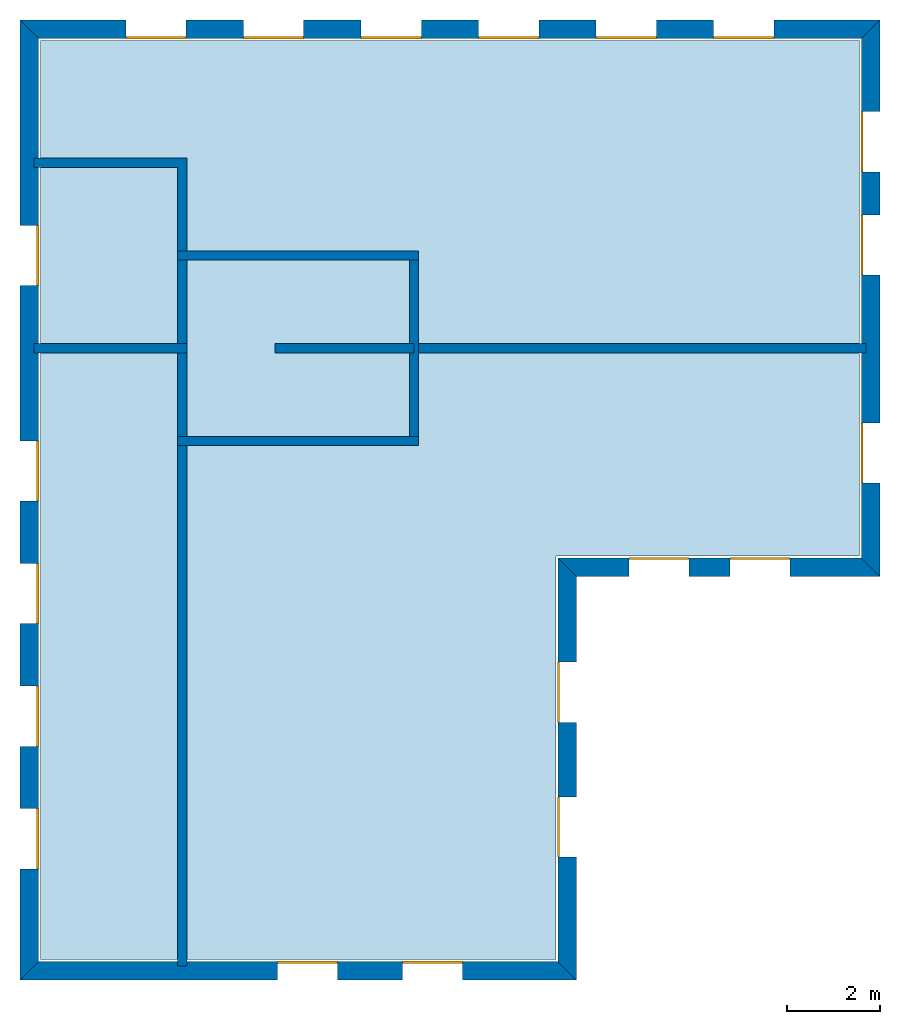
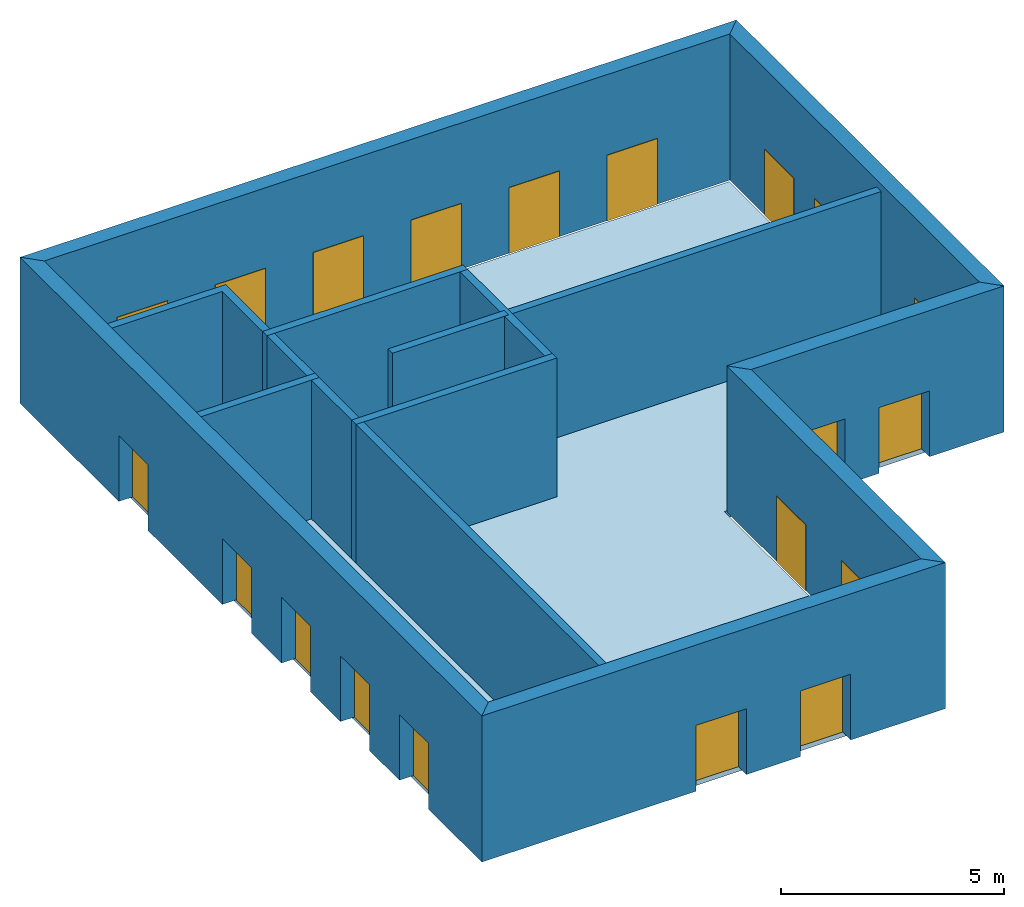
# One storey: 20 windows, 15 walls, 1 slab, 20 openings.
"""IFC4 building model written with IfcOpenShell, lengths in metres."""

import ifcopenshell
import ifcopenshell.guid

model = None  # the IFC model being written
_history = None  # IfcOwnerHistory: only IFC2X3 demands one
_inside = {}  # id of a spatial element -> (the spatial element, [elements in it])
_under = {}  # id of a project, library or spatial element -> (it, [spatial elements below it])
_declared = {}  # id of a project -> (the project, [libraries it declares])
_typed = {}  # id of a type object -> (the type object, [elements of that type])
_made_of = {}  # id of a material, layer set ... -> (it, [elements and type objects made of it])


def new_model(schema):
    """Start an empty IFC model of exactly this schema.

    Asked for "IFC4X3", IfcOpenShell would pick the latest addendum, in which some entities
    have other attributes; the version numbers below select the first issue.
    IFC2X3 requires an IfcOwnerHistory on every rooted entity: one is made here for all.
    """
    global model, _history
    if schema == "IFC4X3":
        model = ifcopenshell.file(schema_version=(4, 3, 0, 0))
    else:
        model = ifcopenshell.file(schema=schema)
    _inside.clear()
    _under.clear()
    _declared.clear()
    _typed.clear()
    _made_of.clear()
    _history = None
    if model.schema == "IFC2X3":
        org = make("IfcOrganization", Name="unknown")
        user = make(
            "IfcPersonAndOrganization",
            ThePerson=make("IfcPerson", FamilyName="unknown"),
            TheOrganization=org,
        )
        app = make(
            "IfcApplication",
            ApplicationDeveloper=org,
            Version="unknown",
            ApplicationFullName="unknown",
            ApplicationIdentifier="unknown",
        )
        _history = make(
            "IfcOwnerHistory",
            OwningUser=user,
            OwningApplication=app,
            ChangeAction="ADDED",
            CreationDate=0,
        )
    return model


def make(cls, **values):
    """One entity of the class cls with the attributes given. An attribute that is None is left unset."""
    return model.create_entity(
        cls, **{name: value for name, value in values.items() if value is not None}
    )


def rooted(cls, **values):
    """An entity with a GlobalId (a new one), such as an element, a storey or a relation."""
    return make(cls, GlobalId=ifcopenshell.guid.new(), OwnerHistory=_history, **values)


def si_unit(unit_type, name, prefix=None):
    """IfcSIUnit, for example si_unit("LENGTHUNIT", "METRE", prefix="MILLI")."""
    return make("IfcSIUnit", UnitType=unit_type, Prefix=prefix, Name=name)


def assignment(units):
    """IfcUnitAssignment: the units of a project."""
    return None if units is None else make("IfcUnitAssignment", Units=units)


def point(xyz):
    """IfcCartesianPoint."""
    return None if xyz is None else make("IfcCartesianPoint", Coordinates=xyz)


def direction(xyz):
    """IfcDirection."""
    return None if xyz is None else make("IfcDirection", DirectionRatios=xyz)


def frame(location, z_axis=None, x_axis=None):
    """IfcAxis2Placement3D, a coordinate frame: its origin and axes. An axis left out is left unset."""
    return make(
        "IfcAxis2Placement3D",
        Location=point(location),
        Axis=direction(z_axis),
        RefDirection=direction(x_axis),
    )


def origin_with_axes():
    """The frame at (0, 0, 0) with the z axis (0, 0, 1) and the x axis (1, 0, 0) written out."""
    return frame((0.0, 0.0, 0.0), z_axis=(0.0, 0.0, 1.0), x_axis=(1.0, 0.0, 0.0))


def place(relative_to, where):
    """IfcLocalPlacement: puts the frame where relative to a parent placement (None: the world)."""
    return make(
        "IfcLocalPlacement", PlacementRelTo=relative_to, RelativePlacement=where
    )


def context(
    kind, dimensions, precision=None, world=None, true_north=None, identifier=None
):
    """IfcGeometricRepresentationContext, for example the 3D "Model" context."""
    return make(
        "IfcGeometricRepresentationContext",
        ContextIdentifier=identifier,
        ContextType=kind,
        CoordinateSpaceDimension=dimensions,
        Precision=precision,
        WorldCoordinateSystem=world,
        TrueNorth=true_north,
    )


def subcontext(parent, identifier, kind, view, scale=None):
    """IfcGeometricRepresentationSubContext, for example "Body" below "Model"."""
    return make(
        "IfcGeometricRepresentationSubContext",
        ContextIdentifier=identifier,
        ContextType=kind,
        ParentContext=parent,
        TargetScale=scale,
        TargetView=view,
    )


def project(units=None, contexts=None):
    """IfcProject with its units and contexts."""
    return rooted(
        "IfcProject",
        Name="project",
        RepresentationContexts=contexts,
        UnitsInContext=assignment(units),
    )


def spatial(cls, under=None, at=None, **own):
    """A site, building, storey or space (cls), placed at a placement, below another one or the project."""
    s = rooted(cls, ObjectPlacement=at, **own)
    if under is not None:
        _under.setdefault(under.id(), (under, []))[1].append(s)
    return s


def point_list(points):
    """IfcCartesianPointList2D or 3D."""
    cls = (
        "IfcCartesianPointList2D" if len(points[0]) == 2 else "IfcCartesianPointList3D"
    )
    return make(cls, CoordList=points)


def line(*indices):
    """IfcLineIndex: a straight run through numbered points of an indexed curve."""
    return model.create_entity("IfcLineIndex", indices)


def indexed_curve(points, segments=None, self_intersect=None):
    """IfcIndexedPolyCurve: lines and arcs through numbered points (the first is 1)."""
    return make(
        "IfcIndexedPolyCurve",
        Points=point_list(points),
        Segments=segments,
        SelfIntersect=self_intersect,
    )


def outline(outer, holes=None, kind="AREA"):
    """IfcArbitraryClosedProfileDef: a profile drawn as a closed curve; with holes, ...WithVoids."""
    if holes is None:
        return make("IfcArbitraryClosedProfileDef", ProfileType=kind, OuterCurve=outer)
    return make(
        "IfcArbitraryProfileDefWithVoids",
        ProfileType=kind,
        OuterCurve=outer,
        InnerCurves=holes,
    )


def extrude(swept, where, along, depth):
    """IfcExtrudedAreaSolid: the profile swept, set in the frame where, extruded along a direction by depth."""
    return make(
        "IfcExtrudedAreaSolid",
        SweptArea=swept,
        Position=where,
        ExtrudedDirection=direction(along),
        Depth=depth,
    )


def shape(context_of_items, identifier, shape_type, items):
    """IfcShapeRepresentation: the items that make up one representation, for example the "Body"."""
    return make(
        "IfcShapeRepresentation",
        ContextOfItems=context_of_items,
        RepresentationIdentifier=identifier,
        RepresentationType=shape_type,
        Items=items,
    )


def made_of(thing, what):
    """Note that an element or type object is made of a material, layer set ...; save() writes the relation."""
    if what is not None:
        _made_of.setdefault(what.id(), (what, []))[1].append(thing)
    return thing


def element(
    cls,
    number,
    at=None,
    inside=None,
    cuts=None,
    type_object=None,
    material=None,
    context=None,
    identifier="Body",
    shape_type=None,
    held_by="IfcProductDefinitionShape",
    body=None,
    shapes=None,
    **own,
):
    """One element of the class cls, such as IfcWall. Its Tag is "e" and its number.

    at: its placement. inside: the storey or other place that contains it. cuts: it is an
    opening in that element (IfcRelVoidsElement). A single representation is given by context,
    identifier, shape_type and body (its items); several are given by shapes. held_by: the class
    of the entity that holds the representations. save() writes the other relations.
    """
    e = rooted(cls, Tag="e%d" % number, ObjectPlacement=at, **own)
    if body is not None:
        shapes = [shape(context, identifier, shape_type, body)]
    if shapes is not None:
        e.Representation = make(held_by, Representations=shapes)
    if inside is not None:
        _inside.setdefault(inside.id(), (inside, []))[1].append(e)
    if cuts is not None:
        rooted(
            "IfcRelVoidsElement", RelatingBuildingElement=cuts, RelatedOpeningElement=e
        )
    if type_object is not None:
        _typed.setdefault(type_object.id(), (type_object, []))[1].append(e)
    return made_of(e, material)


def fill(opening, filler):
    """IfcRelFillsElement: the door or window that sits in an opening."""
    return rooted(
        "IfcRelFillsElement",
        RelatingOpeningElement=opening,
        RelatedBuildingElement=filler,
    )


def aggregate(whole, parts):
    """IfcRelAggregates: a whole, such as a stair, and the parts it consists of."""
    return rooted("IfcRelAggregates", RelatingObject=whole, RelatedObjects=parts)


def save(model, path):
    """Write the relations noted so far, then the file.

    IfcRelAggregates (storeys below a building ...), IfcRelContainedInSpatialStructure (elements
    in a storey), IfcRelDefinesByType, IfcRelAssociatesMaterial and IfcRelDeclares: one each for
    every whole, place, type object, material and project.
    """
    for whole, parts in _under.values():
        aggregate(whole, parts)
    for where, things in _inside.values():
        rooted(
            "IfcRelContainedInSpatialStructure",
            RelatedElements=things,
            RelatingStructure=where,
        )
    for kind, things in _typed.values():
        rooted("IfcRelDefinesByType", RelatedObjects=things, RelatingType=kind)
    for what, things in _made_of.values():
        rooted("IfcRelAssociatesMaterial", RelatedObjects=things, RelatingMaterial=what)
    for by, libraries in _declared.values():
        rooted("IfcRelDeclares", RelatingContext=by, RelatedDefinitions=libraries)
    model.write(path)


model = new_model("IFC4")

# Units and contexts
model_context = context("Model", 3, precision=1e-05, world=origin_with_axes())
body_context = subcontext(model_context, "Body", "Model", "MODEL_VIEW")
ifc_project = project(units=[si_unit("AREAUNIT", "SQUARE_METRE"), si_unit("VOLUMEUNIT", "CUBIC_METRE"), si_unit("LENGTHUNIT", "METRE")], contexts=[model_context])

# Site, building, storey
site = spatial("IfcSite", under=ifc_project)
building = spatial("IfcBuilding", under=site, Name="Building 1")
storey_placement = place(None, origin_with_axes())
storey = spatial("IfcBuildingStorey", under=building, at=storey_placement, Name="01 Storey")

# Slab
slab_placement = place(storey_placement, origin_with_axes())
element("IfcSlab", 1, at=slab_placement, inside=storey, Name="Slab", context=body_context, shape_type="SweptSolid", body=[
    extrude(outline(indexed_curve([(15.553354, 14.695575), (22.099464, 14.695575), (22.099464, 25.815575), (4.433354, 25.815575), (4.433354, 5.9882), (15.553354, 5.9882)], segments=[line(1, 2), line(2, 3), line(3, 4), line(4, 5), line(5, 6)])), origin_with_axes(), (0.0, 0.0, -1.0), 0.2),
])

# Walls
wall_1_placement = place(storey_placement, origin_with_axes())
element("IfcWall", 2, at=wall_1_placement, inside=storey, Name="Wall", context=body_context, shape_type="SweptSolid", body=[
    extrude(outline(indexed_curve([(22.239464, 19.274943), (12.393354, 19.274943), (12.393354, 19.074943), (22.239464, 19.074943)], segments=[line(1, 2), line(2, 3), line(3, 4)])), origin_with_axes(), (0.0, 0.0, 1.0), 3.8),
])
wall_2_placement = place(storey_placement, origin_with_axes())
element("IfcWall", 3, at=wall_2_placement, inside=storey, Name="Wall", context=body_context, shape_type="SweptSolid", body=[
    extrude(outline(indexed_curve([(7.593354, 17.274943), (7.393354, 17.274943), (7.393354, 5.8482), (7.593354, 5.8482)], segments=[line(1, 2), line(2, 3), line(3, 4)])), origin_with_axes(), (0.0, 0.0, 1.0), 3.8),
])
wall_3_placement = place(storey_placement, origin_with_axes())
element("IfcWall", 4, at=wall_3_placement, inside=storey, Name="Wall", context=body_context, shape_type="SweptSolid", body=[
    extrude(outline(indexed_curve([(7.593354, 19.274943), (4.293354, 19.274943), (4.293354, 19.074943), (7.593354, 19.074943)], segments=[line(1, 2), line(2, 3), line(3, 4)])), origin_with_axes(), (0.0, 0.0, 1.0), 3.8),
])
wall_4_placement = place(storey_placement, origin_with_axes())
element("IfcWall", 5, at=wall_4_placement, inside=storey, Name="Wall", context=body_context, shape_type="SweptSolid", body=[
    extrude(outline(indexed_curve([(7.593354, 23.274943), (4.293354, 23.274943), (4.293354, 23.074943), (7.393354, 23.074943), (7.393354, 21.074943), (7.593354, 21.074943)], segments=[line(1, 2), line(2, 3), line(3, 4), line(4, 5), line(5, 6)])), origin_with_axes(), (0.0, 0.0, 1.0), 3.8),
])

# Wall, openings, windows
wall_5_placement = place(storey_placement, origin_with_axes())
wall_5 = element("IfcWall", 6, at=wall_5_placement, inside=storey, Name="Facade", context=body_context, shape_type="SweptSolid", body=[
    extrude(outline(indexed_curve([(15.593354, 14.655575), (22.139464, 14.655575), (22.539464, 14.255575), (15.993354, 14.255575)], segments=[line(1, 2), line(2, 3), line(3, 4)])), origin_with_axes(), (0.0, 0.0, 1.0), 4.0),
])
opening_1_placement = place(wall_5_placement, origin_with_axes())
opening_1 = element("IfcOpeningElement", 7, at=opening_1_placement, cuts=wall_5, Name="Opening", context=body_context, shape_type="SweptSolid", body=[
    extrude(outline(indexed_curve([(17.1253906666667, 14.215575), (17.1253906666667, 14.715575), (18.4253906666667, 14.715575), (18.4253906666667, 14.215575)], segments=[line(1, 2), line(2, 3), line(3, 4)])), origin_with_axes(), (0.0, 0.0, 1.0), 1.8),
])
opening_2_placement = place(wall_5_placement, origin_with_axes())
opening_2 = element("IfcOpeningElement", 8, at=opening_2_placement, cuts=wall_5, Name="Opening", context=body_context, shape_type="SweptSolid", body=[
    extrude(outline(indexed_curve([(19.3074273333333, 14.215575), (19.3074273333333, 14.715575), (20.6074273333333, 14.715575), (20.6074273333333, 14.215575)], segments=[line(1, 2), line(2, 3), line(3, 4)])), origin_with_axes(), (0.0, 0.0, 1.0), 1.8),
])
window_1_placement = place(storey_placement, origin_with_axes())
window_1 = element("IfcWindow", 9, at=window_1_placement, inside=storey, Name="Window", PredefinedType="WINDOW", context=body_context, shape_type="SweptSolid", body=[
    extrude(outline(indexed_curve([(17.1253906666667, 14.615575), (17.1253906666667, 14.665575), (18.4253906666667, 14.665575), (18.4253906666667, 14.615575)], segments=[line(1, 2), line(2, 3), line(3, 4)])), origin_with_axes(), (0.0, 0.0, 1.0), 1.8),
])
fill(opening_1, window_1)
window_2_placement = place(storey_placement, origin_with_axes())
window_2 = element("IfcWindow", 10, at=window_2_placement, inside=storey, Name="Window", PredefinedType="WINDOW", context=body_context, shape_type="SweptSolid", body=[
    extrude(outline(indexed_curve([(19.3074273333333, 14.615575), (19.3074273333333, 14.665575), (20.6074273333333, 14.665575), (20.6074273333333, 14.615575)], segments=[line(1, 2), line(2, 3), line(3, 4)])), origin_with_axes(), (0.0, 0.0, 1.0), 1.8),
])
fill(opening_2, window_2)

wall_6_placement = place(storey_placement, origin_with_axes())
wall_6 = element("IfcWall", 11, at=wall_6_placement, inside=storey, Name="Facade", context=body_context, shape_type="SweptSolid", body=[
    extrude(outline(indexed_curve([(22.139464, 14.655575), (22.139464, 25.855575), (22.539464, 26.255575), (22.539464, 14.255575)], segments=[line(1, 2), line(2, 3), line(3, 4)])), origin_with_axes(), (0.0, 0.0, 1.0), 4.0),
])
opening_3_placement = place(wall_6_placement, origin_with_axes())
opening_3 = element("IfcOpeningElement", 12, at=opening_3_placement, cuts=wall_6, Name="Opening", context=body_context, shape_type="SweptSolid", body=[
    extrude(outline(indexed_curve([(22.579464, 16.265259), (22.079464, 16.265259), (22.079464, 17.565259), (22.579464, 17.565259)], segments=[line(1, 2), line(2, 3), line(3, 4)])), origin_with_axes(), (0.0, 0.0, 1.0), 1.8),
])
opening_4_placement = place(wall_6_placement, origin_with_axes())
opening_4 = element("IfcOpeningElement", 13, at=opening_4_placement, cuts=wall_6, Name="Opening", context=body_context, shape_type="SweptSolid", body=[
    extrude(outline(indexed_curve([(22.579464, 20.7518203333333), (22.079464, 20.7518203333333), (22.079464, 22.0518203333333), (22.579464, 22.0518203333333)], segments=[line(1, 2), line(2, 3), line(3, 4)])), origin_with_axes(), (0.0, 0.0, 1.0), 1.8),
])
opening_5_placement = place(wall_6_placement, origin_with_axes())
opening_5 = element("IfcOpeningElement", 14, at=opening_5_placement, cuts=wall_6, Name="Opening", context=body_context, shape_type="SweptSolid", body=[
    extrude(outline(indexed_curve([(22.579464, 22.9786976666667), (22.079464, 22.9786976666667), (22.079464, 24.2786976666667), (22.579464, 24.2786976666667)], segments=[line(1, 2), line(2, 3), line(3, 4)])), origin_with_axes(), (0.0, 0.0, 1.0), 1.8),
])
window_3_placement = place(storey_placement, origin_with_axes())
window_3 = element("IfcWindow", 15, at=window_3_placement, inside=storey, Name="Window", PredefinedType="WINDOW", context=body_context, shape_type="SweptSolid", body=[
    extrude(outline(indexed_curve([(22.179464, 16.265259), (22.129464, 16.265259), (22.129464, 17.565259), (22.179464, 17.565259)], segments=[line(1, 2), line(2, 3), line(3, 4)])), origin_with_axes(), (0.0, 0.0, 1.0), 1.8),
])
fill(opening_3, window_3)
window_4_placement = place(storey_placement, origin_with_axes())
window_4 = element("IfcWindow", 16, at=window_4_placement, inside=storey, Name="Window", PredefinedType="WINDOW", context=body_context, shape_type="SweptSolid", body=[
    extrude(outline(indexed_curve([(22.179464, 20.7518203333333), (22.129464, 20.7518203333333), (22.129464, 22.0518203333333), (22.179464, 22.0518203333333)], segments=[line(1, 2), line(2, 3), line(3, 4)])), origin_with_axes(), (0.0, 0.0, 1.0), 1.8),
])
fill(opening_4, window_4)
window_5_placement = place(storey_placement, origin_with_axes())
window_5 = element("IfcWindow", 17, at=window_5_placement, inside=storey, Name="Window", PredefinedType="WINDOW", context=body_context, shape_type="SweptSolid", body=[
    extrude(outline(indexed_curve([(22.179464, 22.9786976666667), (22.129464, 22.9786976666667), (22.129464, 24.2786976666667), (22.179464, 24.2786976666667)], segments=[line(1, 2), line(2, 3), line(3, 4)])), origin_with_axes(), (0.0, 0.0, 1.0), 1.8),
])
fill(opening_5, window_5)

wall_7_placement = place(storey_placement, origin_with_axes())
wall_7 = element("IfcWall", 18, at=wall_7_placement, inside=storey, Name="Facade", context=body_context, shape_type="SweptSolid", body=[
    extrude(outline(indexed_curve([(22.139464, 25.855575), (4.393354, 25.855575), (3.993354, 26.255575), (22.539464, 26.255575)], segments=[line(1, 2), line(2, 3), line(3, 4)])), origin_with_axes(), (0.0, 0.0, 1.0), 4.0),
])
opening_6_placement = place(wall_7_placement, origin_with_axes())
opening_6 = element("IfcOpeningElement", 19, at=opening_6_placement, cuts=wall_7, Name="Opening", context=body_context, shape_type="SweptSolid", body=[
    extrude(outline(indexed_curve([(20.2543054285714, 26.295575), (20.2543054285714, 25.795575), (18.9543054285714, 25.795575), (18.9543054285714, 26.295575)], segments=[line(1, 2), line(2, 3), line(3, 4)])), origin_with_axes(), (0.0, 0.0, 1.0), 1.8),
])
opening_7_placement = place(wall_7_placement, origin_with_axes())
opening_7 = element("IfcOpeningElement", 20, at=opening_7_placement, cuts=wall_7, Name="Opening", context=body_context, shape_type="SweptSolid", body=[
    extrude(outline(indexed_curve([(17.7191468571429, 26.295575), (17.7191468571429, 25.795575), (16.4191468571429, 25.795575), (16.4191468571429, 26.295575)], segments=[line(1, 2), line(2, 3), line(3, 4)])), origin_with_axes(), (0.0, 0.0, 1.0), 1.8),
])
opening_8_placement = place(wall_7_placement, origin_with_axes())
opening_8 = element("IfcOpeningElement", 21, at=opening_8_placement, cuts=wall_7, Name="Opening", context=body_context, shape_type="SweptSolid", body=[
    extrude(outline(indexed_curve([(15.1839882857143, 26.295575), (15.1839882857143, 25.795575), (13.8839882857143, 25.795575), (13.8839882857143, 26.295575)], segments=[line(1, 2), line(2, 3), line(3, 4)])), origin_with_axes(), (0.0, 0.0, 1.0), 1.8),
])
opening_9_placement = place(wall_7_placement, origin_with_axes())
opening_9 = element("IfcOpeningElement", 22, at=opening_9_placement, cuts=wall_7, Name="Opening", context=body_context, shape_type="SweptSolid", body=[
    extrude(outline(indexed_curve([(12.6488297142857, 26.295575), (12.6488297142857, 25.795575), (11.3488297142857, 25.795575), (11.3488297142857, 26.295575)], segments=[line(1, 2), line(2, 3), line(3, 4)])), origin_with_axes(), (0.0, 0.0, 1.0), 1.8),
])
opening_10_placement = place(wall_7_placement, origin_with_axes())
opening_10 = element("IfcOpeningElement", 23, at=opening_10_placement, cuts=wall_7, Name="Opening", context=body_context, shape_type="SweptSolid", body=[
    extrude(outline(indexed_curve([(10.1136711428571, 26.295575), (10.1136711428571, 25.795575), (8.81367114285714, 25.795575), (8.81367114285714, 26.295575)], segments=[line(1, 2), line(2, 3), line(3, 4)])), origin_with_axes(), (0.0, 0.0, 1.0), 1.8),
])
opening_11_placement = place(wall_7_placement, origin_with_axes())
opening_11 = element("IfcOpeningElement", 24, at=opening_11_placement, cuts=wall_7, Name="Opening", context=body_context, shape_type="SweptSolid", body=[
    extrude(outline(indexed_curve([(7.57851257142857, 26.295575), (7.57851257142857, 25.795575), (6.27851257142857, 25.795575), (6.27851257142857, 26.295575)], segments=[line(1, 2), line(2, 3), line(3, 4)])), origin_with_axes(), (0.0, 0.0, 1.0), 1.8),
])
window_6_placement = place(storey_placement, origin_with_axes())
window_6 = element("IfcWindow", 25, at=window_6_placement, inside=storey, Name="Window", PredefinedType="WINDOW", context=body_context, shape_type="SweptSolid", body=[
    extrude(outline(indexed_curve([(20.2543054285714, 25.895575), (20.2543054285714, 25.845575), (18.9543054285714, 25.845575), (18.9543054285714, 25.895575)], segments=[line(1, 2), line(2, 3), line(3, 4)])), origin_with_axes(), (0.0, 0.0, 1.0), 1.8),
])
fill(opening_6, window_6)
window_7_placement = place(storey_placement, origin_with_axes())
window_7 = element("IfcWindow", 26, at=window_7_placement, inside=storey, Name="Window", PredefinedType="WINDOW", context=body_context, shape_type="SweptSolid", body=[
    extrude(outline(indexed_curve([(17.7191468571429, 25.895575), (17.7191468571429, 25.845575), (16.4191468571429, 25.845575), (16.4191468571429, 25.895575)], segments=[line(1, 2), line(2, 3), line(3, 4)])), origin_with_axes(), (0.0, 0.0, 1.0), 1.8),
])
fill(opening_7, window_7)
window_8_placement = place(storey_placement, origin_with_axes())
window_8 = element("IfcWindow", 27, at=window_8_placement, inside=storey, Name="Window", PredefinedType="WINDOW", context=body_context, shape_type="SweptSolid", body=[
    extrude(outline(indexed_curve([(15.1839882857143, 25.895575), (15.1839882857143, 25.845575), (13.8839882857143, 25.845575), (13.8839882857143, 25.895575)], segments=[line(1, 2), line(2, 3), line(3, 4)])), origin_with_axes(), (0.0, 0.0, 1.0), 1.8),
])
fill(opening_8, window_8)
window_9_placement = place(storey_placement, origin_with_axes())
window_9 = element("IfcWindow", 28, at=window_9_placement, inside=storey, Name="Window", PredefinedType="WINDOW", context=body_context, shape_type="SweptSolid", body=[
    extrude(outline(indexed_curve([(12.6488297142857, 25.895575), (12.6488297142857, 25.845575), (11.3488297142857, 25.845575), (11.3488297142857, 25.895575)], segments=[line(1, 2), line(2, 3), line(3, 4)])), origin_with_axes(), (0.0, 0.0, 1.0), 1.8),
])
fill(opening_9, window_9)
window_10_placement = place(storey_placement, origin_with_axes())
window_10 = element("IfcWindow", 29, at=window_10_placement, inside=storey, Name="Window", PredefinedType="WINDOW", context=body_context, shape_type="SweptSolid", body=[
    extrude(outline(indexed_curve([(10.1136711428571, 25.895575), (10.1136711428571, 25.845575), (8.81367114285714, 25.845575), (8.81367114285714, 25.895575)], segments=[line(1, 2), line(2, 3), line(3, 4)])), origin_with_axes(), (0.0, 0.0, 1.0), 1.8),
])
fill(opening_10, window_10)
window_11_placement = place(storey_placement, origin_with_axes())
window_11 = element("IfcWindow", 30, at=window_11_placement, inside=storey, Name="Window", PredefinedType="WINDOW", context=body_context, shape_type="SweptSolid", body=[
    extrude(outline(indexed_curve([(7.57851257142857, 25.895575), (7.57851257142857, 25.845575), (6.27851257142857, 25.845575), (6.27851257142857, 25.895575)], segments=[line(1, 2), line(2, 3), line(3, 4)])), origin_with_axes(), (0.0, 0.0, 1.0), 1.8),
])
fill(opening_11, window_11)

wall_8_placement = place(storey_placement, origin_with_axes())
wall_8 = element("IfcWall", 31, at=wall_8_placement, inside=storey, Name="Facade", context=body_context, shape_type="SweptSolid", body=[
    extrude(outline(indexed_curve([(4.393354, 25.855575), (4.393354, 5.9482), (3.993354, 5.5482), (3.993354, 26.255575)], segments=[line(1, 2), line(2, 3), line(3, 4)])), origin_with_axes(), (0.0, 0.0, 1.0), 4.0),
])
opening_12_placement = place(wall_8_placement, origin_with_axes())
opening_12 = element("IfcOpeningElement", 32, at=opening_12_placement, cuts=wall_8, Name="Opening", context=body_context, shape_type="SweptSolid", body=[
    extrude(outline(indexed_curve([(3.953354, 17.1795944), (4.453354, 17.1795944), (4.453354, 15.8795944), (3.953354, 15.8795944)], segments=[line(1, 2), line(2, 3), line(3, 4)])), origin_with_axes(), (0.0, 0.0, 1.0), 1.8),
])
opening_13_placement = place(wall_8_placement, origin_with_axes())
opening_13 = element("IfcOpeningElement", 33, at=opening_13_placement, cuts=wall_8, Name="Opening", context=body_context, shape_type="SweptSolid", body=[
    extrude(outline(indexed_curve([(3.953354, 14.5342458), (4.453354, 14.5342458), (4.453354, 13.2342458), (3.953354, 13.2342458)], segments=[line(1, 2), line(2, 3), line(3, 4)])), origin_with_axes(), (0.0, 0.0, 1.0), 1.8),
])
opening_14_placement = place(wall_8_placement, origin_with_axes())
opening_14 = element("IfcOpeningElement", 34, at=opening_14_placement, cuts=wall_8, Name="Opening", context=body_context, shape_type="SweptSolid", body=[
    extrude(outline(indexed_curve([(3.953354, 11.8888972), (4.453354, 11.8888972), (4.453354, 10.5888972), (3.953354, 10.5888972)], segments=[line(1, 2), line(2, 3), line(3, 4)])), origin_with_axes(), (0.0, 0.0, 1.0), 1.8),
])
opening_15_placement = place(wall_8_placement, origin_with_axes())
opening_15 = element("IfcOpeningElement", 35, at=opening_15_placement, cuts=wall_8, Name="Opening", context=body_context, shape_type="SweptSolid", body=[
    extrude(outline(indexed_curve([(3.953354, 9.2435486), (4.453354, 9.2435486), (4.453354, 7.9435486), (3.953354, 7.9435486)], segments=[line(1, 2), line(2, 3), line(3, 4)])), origin_with_axes(), (0.0, 0.0, 1.0), 1.8),
])
opening_16_placement = place(wall_8_placement, origin_with_axes())
opening_16 = element("IfcOpeningElement", 36, at=opening_16_placement, cuts=wall_8, Name="Opening", context=body_context, shape_type="SweptSolid", body=[
    extrude(outline(indexed_curve([(3.953354, 21.824943), (4.453354, 21.824943), (4.453354, 20.524943), (3.953354, 20.524943)], segments=[line(1, 2), line(2, 3), line(3, 4)])), origin_with_axes(), (0.0, 0.0, 1.0), 1.8),
])
window_12_placement = place(storey_placement, origin_with_axes())
window_12 = element("IfcWindow", 37, at=window_12_placement, inside=storey, Name="Window", PredefinedType="WINDOW", context=body_context, shape_type="SweptSolid", body=[
    extrude(outline(indexed_curve([(4.353354, 17.1795944), (4.403354, 17.1795944), (4.403354, 15.8795944), (4.353354, 15.8795944)], segments=[line(1, 2), line(2, 3), line(3, 4)])), origin_with_axes(), (0.0, 0.0, 1.0), 1.8),
])
fill(opening_12, window_12)
window_13_placement = place(storey_placement, origin_with_axes())
window_13 = element("IfcWindow", 38, at=window_13_placement, inside=storey, Name="Window", PredefinedType="WINDOW", context=body_context, shape_type="SweptSolid", body=[
    extrude(outline(indexed_curve([(4.353354, 14.5342458), (4.403354, 14.5342458), (4.403354, 13.2342458), (4.353354, 13.2342458)], segments=[line(1, 2), line(2, 3), line(3, 4)])), origin_with_axes(), (0.0, 0.0, 1.0), 1.8),
])
fill(opening_13, window_13)
window_14_placement = place(storey_placement, origin_with_axes())
window_14 = element("IfcWindow", 39, at=window_14_placement, inside=storey, Name="Window", PredefinedType="WINDOW", context=body_context, shape_type="SweptSolid", body=[
    extrude(outline(indexed_curve([(4.353354, 11.8888972), (4.403354, 11.8888972), (4.403354, 10.5888972), (4.353354, 10.5888972)], segments=[line(1, 2), line(2, 3), line(3, 4)])), origin_with_axes(), (0.0, 0.0, 1.0), 1.8),
])
fill(opening_14, window_14)
window_15_placement = place(storey_placement, origin_with_axes())
window_15 = element("IfcWindow", 40, at=window_15_placement, inside=storey, Name="Window", PredefinedType="WINDOW", context=body_context, shape_type="SweptSolid", body=[
    extrude(outline(indexed_curve([(4.353354, 9.2435486), (4.403354, 9.2435486), (4.403354, 7.9435486), (4.353354, 7.9435486)], segments=[line(1, 2), line(2, 3), line(3, 4)])), origin_with_axes(), (0.0, 0.0, 1.0), 1.8),
])
fill(opening_15, window_15)
window_16_placement = place(storey_placement, origin_with_axes())
window_16 = element("IfcWindow", 41, at=window_16_placement, inside=storey, Name="Window", PredefinedType="WINDOW", context=body_context, shape_type="SweptSolid", body=[
    extrude(outline(indexed_curve([(4.353354, 21.824943), (4.403354, 21.824943), (4.403354, 20.524943), (4.353354, 20.524943)], segments=[line(1, 2), line(2, 3), line(3, 4)])), origin_with_axes(), (0.0, 0.0, 1.0), 1.8),
])
fill(opening_16, window_16)

wall_9_placement = place(storey_placement, origin_with_axes())
wall_9 = element("IfcWall", 42, at=wall_9_placement, inside=storey, Name="Facade", context=body_context, shape_type="SweptSolid", body=[
    extrude(outline(indexed_curve([(4.393354, 5.9482), (15.593354, 5.9482), (15.993354, 5.5482), (3.993354, 5.5482)], segments=[line(1, 2), line(2, 3), line(3, 4)])), origin_with_axes(), (0.0, 0.0, 1.0), 4.0),
])
opening_17_placement = place(wall_9_placement, origin_with_axes())
opening_17 = element("IfcOpeningElement", 43, at=opening_17_placement, cuts=wall_9, Name="Opening", context=body_context, shape_type="SweptSolid", body=[
    extrude(outline(indexed_curve([(9.543354, 5.5082), (9.543354, 6.0082), (10.843354, 6.0082), (10.843354, 5.5082)], segments=[line(1, 2), line(2, 3), line(3, 4)])), origin_with_axes(), (0.0, 0.0, 1.0), 1.8),
])
opening_18_placement = place(wall_9_placement, origin_with_axes())
opening_18 = element("IfcOpeningElement", 44, at=opening_18_placement, cuts=wall_9, Name="Opening", context=body_context, shape_type="SweptSolid", body=[
    extrude(outline(indexed_curve([(12.243354, 5.5082), (12.243354, 6.0082), (13.543354, 6.0082), (13.543354, 5.5082)], segments=[line(1, 2), line(2, 3), line(3, 4)])), origin_with_axes(), (0.0, 0.0, 1.0), 1.8),
])
window_17_placement = place(storey_placement, origin_with_axes())
window_17 = element("IfcWindow", 45, at=window_17_placement, inside=storey, Name="Window", PredefinedType="WINDOW", context=body_context, shape_type="SweptSolid", body=[
    extrude(outline(indexed_curve([(9.543354, 5.9082), (9.543354, 5.9582), (10.843354, 5.9582), (10.843354, 5.9082)], segments=[line(1, 2), line(2, 3), line(3, 4)])), origin_with_axes(), (0.0, 0.0, 1.0), 1.8),
])
fill(opening_17, window_17)
window_18_placement = place(storey_placement, origin_with_axes())
window_18 = element("IfcWindow", 46, at=window_18_placement, inside=storey, Name="Window", PredefinedType="WINDOW", context=body_context, shape_type="SweptSolid", body=[
    extrude(outline(indexed_curve([(12.243354, 5.9082), (12.243354, 5.9582), (13.543354, 5.9582), (13.543354, 5.9082)], segments=[line(1, 2), line(2, 3), line(3, 4)])), origin_with_axes(), (0.0, 0.0, 1.0), 1.8),
])
fill(opening_18, window_18)

wall_10_placement = place(storey_placement, origin_with_axes())
wall_10 = element("IfcWall", 47, at=wall_10_placement, inside=storey, Name="Facade", context=body_context, shape_type="SweptSolid", body=[
    extrude(outline(indexed_curve([(15.593354, 5.9482), (15.593354, 14.655575), (15.993354, 14.255575), (15.993354, 5.5482)], segments=[line(1, 2), line(2, 3), line(3, 4)])), origin_with_axes(), (0.0, 0.0, 1.0), 4.0),
])
opening_19_placement = place(wall_10_placement, origin_with_axes())
opening_19 = element("IfcOpeningElement", 48, at=opening_19_placement, cuts=wall_10, Name="Opening", context=body_context, shape_type="SweptSolid", body=[
    extrude(outline(indexed_curve([(16.033354, 8.20065833333333), (15.533354, 8.20065833333333), (15.533354, 9.50065833333333), (16.033354, 9.50065833333333)], segments=[line(1, 2), line(2, 3), line(3, 4)])), origin_with_axes(), (0.0, 0.0, 1.0), 1.8),
])
opening_20_placement = place(wall_10_placement, origin_with_axes())
opening_20 = element("IfcOpeningElement", 49, at=opening_20_placement, cuts=wall_10, Name="Opening", context=body_context, shape_type="SweptSolid", body=[
    extrude(outline(indexed_curve([(16.033354, 11.1031166666667), (15.533354, 11.1031166666667), (15.533354, 12.4031166666667), (16.033354, 12.4031166666667)], segments=[line(1, 2), line(2, 3), line(3, 4)])), origin_with_axes(), (0.0, 0.0, 1.0), 1.8),
])
window_19_placement = place(storey_placement, origin_with_axes())
window_19 = element("IfcWindow", 50, at=window_19_placement, inside=storey, Name="Window", PredefinedType="WINDOW", context=body_context, shape_type="SweptSolid", body=[
    extrude(outline(indexed_curve([(15.633354, 8.20065833333333), (15.583354, 8.20065833333333), (15.583354, 9.50065833333333), (15.633354, 9.50065833333333)], segments=[line(1, 2), line(2, 3), line(3, 4)])), origin_with_axes(), (0.0, 0.0, 1.0), 1.8),
])
fill(opening_19, window_19)
window_20_placement = place(storey_placement, origin_with_axes())
window_20 = element("IfcWindow", 51, at=window_20_placement, inside=storey, Name="Window", PredefinedType="WINDOW", context=body_context, shape_type="SweptSolid", body=[
    extrude(outline(indexed_curve([(15.633354, 11.1031166666667), (15.583354, 11.1031166666667), (15.583354, 12.4031166666667), (15.633354, 12.4031166666667)], segments=[line(1, 2), line(2, 3), line(3, 4)])), origin_with_axes(), (0.0, 0.0, 1.0), 1.8),
])
fill(opening_20, window_20)

# Walls
wall_11_placement = place(storey_placement, origin_with_axes())
element("IfcWall", 52, at=wall_11_placement, inside=storey, Name="CoreWall", context=body_context, shape_type="SweptSolid", body=[
    extrude(outline(indexed_curve([(12.593354, 21.274943), (7.393354, 21.274943), (7.393354, 21.074943), (12.593354, 21.074943)], segments=[line(1, 2), line(2, 3), line(3, 4)])), origin_with_axes(), (0.0, 0.0, 1.0), 3.8),
])
wall_12_placement = place(storey_placement, origin_with_axes())
element("IfcWall", 53, at=wall_12_placement, inside=storey, Name="CoreWall", context=body_context, shape_type="SweptSolid", body=[
    extrude(outline(indexed_curve([(7.393354, 17.074943), (12.593354, 17.074943), (12.593354, 17.274943), (7.393354, 17.274943)], segments=[line(1, 2), line(2, 3), line(3, 4)])), origin_with_axes(), (0.0, 0.0, 1.0), 3.8),
])
wall_13_placement = place(storey_placement, origin_with_axes())
element("IfcWall", 54, at=wall_13_placement, inside=storey, Name="CoreWall", context=body_context, shape_type="SweptSolid", body=[
    extrude(outline(indexed_curve([(7.593354, 17.274943), (7.593354, 21.074943), (7.393354, 21.074943), (7.393354, 17.274943)], segments=[line(1, 2), line(2, 3), line(3, 4)])), origin_with_axes(), (0.0, 0.0, 1.0), 3.8),
])
wall_14_placement = place(storey_placement, origin_with_axes())
element("IfcWall", 55, at=wall_14_placement, inside=storey, Name="CoreWall", context=body_context, shape_type="SweptSolid", body=[
    extrude(outline(indexed_curve([(12.393354, 21.074943), (12.393354, 17.274943), (12.593354, 17.274943), (12.593354, 21.074943)], segments=[line(1, 2), line(2, 3), line(3, 4)])), origin_with_axes(), (0.0, 0.0, 1.0), 3.8),
])
wall_15_placement = place(storey_placement, origin_with_axes())
element("IfcWall", 56, at=wall_15_placement, inside=storey, Name="CoreWall", context=body_context, shape_type="SweptSolid", body=[
    extrude(outline(indexed_curve([(12.493354, 19.274943), (9.493354, 19.274943), (9.493354, 19.074943), (12.493354, 19.074943)], segments=[line(1, 2), line(2, 3), line(3, 4)])), origin_with_axes(), (0.0, 0.0, 1.0), 3.8),
])

save(model, "model.ifc")
